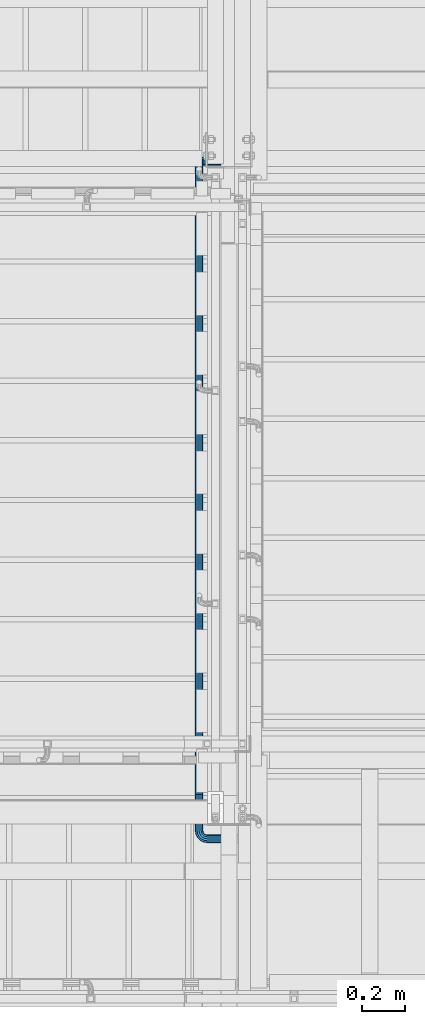
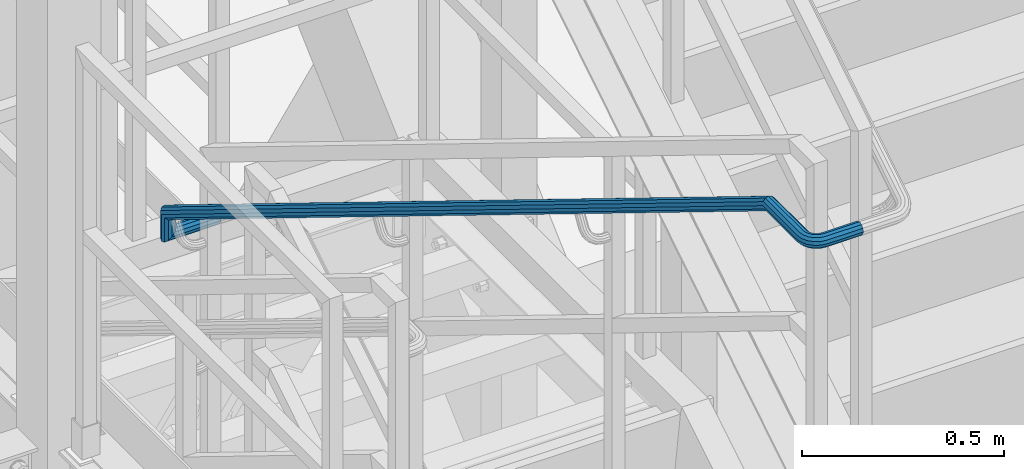
# One storey, part 1764 of 3843: 1 beam, 1 element without a shape of its own.
"""IFC2X3 building model written with IfcOpenShell, lengths in millimetres."""

from ifc_helpers import new_model, si_unit, frame, origin_with_axes, place, context, subcontext, project, spatial, faceted_brep, material, type_object, element, aggregate, save


model = new_model("IFC2X3")

# Units and contexts
model_context = context("Model", 3, precision=1e-05, world=origin_with_axes())
body_context = subcontext(model_context, "Body", "Model", "MODEL_VIEW")
ifc_project = project(units=[si_unit("LENGTHUNIT", "METRE", prefix="MILLI"), si_unit("AREAUNIT", "SQUARE_METRE"), si_unit("VOLUMEUNIT", "CUBIC_METRE"), si_unit("MASSUNIT", "GRAM", prefix="KILO"), si_unit("TIMEUNIT", "SECOND"), si_unit("PLANEANGLEUNIT", "RADIAN"), si_unit("SOLIDANGLEUNIT", "STERADIAN"), si_unit("THERMODYNAMICTEMPERATUREUNIT", "DEGREE_CELSIUS"), si_unit("LUMINOUSINTENSITYUNIT", "LUMEN")], contexts=[model_context])

# Site, building, storey
site_placement = place(None, origin_with_axes())
site = spatial("IfcSite", under=ifc_project, at=site_placement, CompositionType="ELEMENT")
building_placement = place(site_placement, origin_with_axes())
building = spatial("IfcBuilding", under=site, at=building_placement, Name="Undefined", CompositionType="ELEMENT")
storey_placement = place(building_placement, origin_with_axes())
storey = spatial("IfcBuildingStorey", under=building, at=storey_placement, Name="Undefined", CompositionType="ELEMENT", Elevation=0.0)

# Assembly, beam
assembly_placement = place(storey_placement, origin_with_axes())
assembly = element("IfcElementAssembly", 1, at=assembly_placement, inside=storey, Name="RAIL", AssemblyPlace="NOTDEFINED", PredefinedType="RIGID_FRAME")
ifc_material = material(Name="STEEL/A513")
beam_type = type_object("IfcBeamType", PredefinedType="NOTDEFINED")
beam_placement = place(assembly_placement, frame((54381.4, 21932.9, 33973.4769213163), z_axis=(0.0, -1.0, 0.0), x_axis=(-1.0, 0.0, 0.0)))
beam = element("IfcBeam", 2, at=beam_placement, type_object=beam_type, material=ifc_material, Name="GRAB RAIL", context=body_context, shape_type="Brep", body=[
    faceted_brep([(0.0, -19.0500000000029, 0.0), (0.0, -16.4977839420972, -9.52500000000146), (120.149999999972, -16.4977839420972, -9.52500000000146), (120.149999999972, -19.0500000000029, 0.0), (0.0, -9.52500000000146, -16.4977839420972), (120.149999999972, -9.52500000000146, -16.4977839420935), (0.0, 0.0, -19.0499989999989), (120.149999999972, 0.0, -19.0499999999993), (0.0, 9.52500000000146, -16.4977839420972), (120.149999999972, 9.52500000000146, -16.4977839420935), (0.0, 16.4977839420972, -9.52500000000146), (120.149999999972, 16.4977839420972, -9.52500000000146), (0.0, 19.0500000000029, 0.0), (120.149999999972, 19.0500000000029, 0.0), (0.0, 16.4977839420972, 9.52500000000146), (120.149999999972, 16.4977839420972, 9.52500000000146), (0.0, 9.52500000000146, 16.4977839420972), (120.149999999972, 9.52500000000146, 16.4977839420935), (0.0, 0.0, 19.0499989999989), (120.149999999972, 0.0, 19.0499999999993), (0.0, -9.52500000000146, 16.4977839420972), (120.149999999972, -9.52500000000146, 16.4977839420935), (0.0, -16.4977839420972, 9.52500000000146), (120.149999999972, -16.4977839420972, 9.52500000000146), (0.0, -15.875, 0.0), (0.0, -13.7481532850798, 7.9375), (120.149999999972, -13.7481532850798, 7.9375), (120.149999999972, -15.875, 0.0), (0.0, -7.9375, 13.7481532850798), (120.149999999972, -7.9375, 13.7481532850798), (0.0, 0.0, 15.875), (120.149999999972, 0.0, 15.875), (0.0, 7.9375, 13.7481532850798), (120.149999999972, 7.9375, 13.7481532850798), (0.0, 13.7481532850798, 7.9375), (120.149999999972, 13.7481532850798, 7.9375), (0.0, 15.875, 0.0), (120.149999999972, 15.875, 0.0), (0.0, 13.7481532850798, -7.9375), (120.149999999972, 13.7481532850798, -7.9375), (0.0, 7.9375, -13.7481532850798), (120.149999999972, 7.9375, -13.7481532850798), (0.0, 0.0, -15.875), (120.149999999972, 0.0, -15.875), (0.0, -7.9375, -13.7481532850798), (120.149999999972, -7.9375, -13.7481532850798), (0.0, -13.7481532850798, -7.9375), (120.149999999972, -13.7481532850798, -7.9375), (123.202216057878, -16.4977839420972, -9.52500000000146), (120.649999999972, -19.0500000000029, 0.0), (130.174999999974, -9.52500000000146, -16.4977839420935), (139.699999999975, 0.0, -19.0499999999993), (149.224999999977, 9.52500000000146, -16.4977839420935), (156.197783942072, 16.4977839420972, -9.52500000000146), (158.749999999978, 19.0500000000029, 0.0), (156.197783942072, 16.4977839420972, 9.52500000000146), (149.224999999977, 9.52500000000146, 16.4977839420935), (139.699999999975, 0.0, 19.0499999999993), (130.174999999974, -9.52500000000146, 16.4977839420935), (123.202216057878, -16.4977839420972, 9.52500000000146), (125.951846714896, -13.7481532850798, 7.9375), (123.824999999975, -15.875, 0.0), (131.762499999975, -7.9375, 13.7481532850798), (139.699999999975, 0.0, 15.875), (147.637499999975, 7.9375, 13.7481532850798), (153.448153285055, 13.7481532850798, 7.9375), (155.574999999975, 15.875, 0.0), (153.448153285055, 13.7481532850798, -7.9375), (147.637499999975, 7.9375, -13.7481532850798), (139.699999999975, 0.0, -15.875), (131.762499999975, -7.9375, -13.7481532850798), (125.951846714896, -13.7481532850798, -7.9375), (123.202216057878, -19.5500000000029, -9.52500000000146), (120.649999999972, -19.5500000000029, 0.0), (130.174999999974, -19.5500000000029, -16.4977839420935), (139.699999999975, -19.5500000000029, -19.0499999999993), (149.224999999977, -19.5500000000029, -16.4977839420935), (156.197783942072, -19.5500000000029, -9.52500000000146), (158.749999999978, -19.5500000000029, 0.0), (156.197783942072, -19.5500000000029, 9.52500000000146), (149.224999999977, -19.5500000000029, 16.4977839420935), (139.699999999975, -19.5500000000029, 19.0499999999993), (130.174999999974, -19.5500000000029, 16.4977839420935), (123.202216057878, -19.5500000000029, 9.52500000000146), (125.951846714896, -19.5500000000029, 7.9375), (123.824999999975, -19.5500000000029, 0.0), (131.762499999975, -19.5500000000029, 13.7481532850798), (139.699999999975, -19.5500000000029, 15.875), (147.637499999975, -19.5500000000029, 13.7481532850798), (153.448153285055, -19.5500000000029, 7.9375), (155.574999999975, -19.5500000000029, 0.0), (153.448153285055, -19.5500000000029, -7.9375), (147.637499999975, -19.5500000000029, -13.7481532850798), (139.699999999975, -19.5500000000029, -15.875), (131.762499999975, -19.5500000000029, -13.7481532850798), (125.951846714896, -19.5500000000029, -7.9375), (123.202216057878, -51.3780302253144, -9.52500000000146), (120.649999999972, -51.3780302253144, 0.0), (130.174999999974, -51.3780302253144, -16.4977839420935), (139.699999999975, -51.3780302253144, -19.0499999999993), (149.224999999977, -51.3780302253144, -16.4977839420935), (156.197783942072, -51.3780302253144, -9.52500000000146), (158.749999999978, -51.3780302253144, 0.0), (156.197783942072, -51.3780302253144, 9.52500000000146), (149.224999999977, -51.3780302253144, 16.4977839420935), (139.699999999975, -51.3780302253144, 19.0499999999993), (130.174999999974, -51.3780302253144, 16.4977839420935), (123.202216057878, -51.3780302253144, 9.52500000000146), (125.951846714896, -51.3780302253144, 7.9375), (123.824999999975, -51.3780302253144, 0.0), (131.762499999975, -51.3780302253144, 13.7481532850798), (139.699999999975, -51.3780302253144, 15.875), (147.637499999975, -51.3780302253144, 13.7481532850798), (153.448153285055, -51.3780302253144, 7.9375), (155.574999999975, -51.3780302253144, 0.0), (153.448153285055, -51.3780302253144, -7.9375), (147.637499999975, -51.3780302253144, -13.7481532850798), (139.699999999975, -51.3780302253144, -15.875), (131.762499999975, -51.3780302253144, -13.7481532850798), (125.951846714896, -51.3780302253144, -7.9375), (123.202216057878, -67.8456029129011, -9.52500000000146), (120.649999999972, -62.5230786837055, 0.0), (130.174999999974, -71.7419610731886, -16.4977839420935), (139.699999999975, -73.1681271420966, -19.0499999999993), (149.224999999977, -71.7419610731886, -16.4977839420935), (156.197783942072, -67.8456029129011, -9.52500000000146), (158.749999999978, -62.5230786837055, 0.0), (156.197783942072, -57.20055445451, 9.52500000000146), (149.224999999977, -53.3041962942225, 16.4977839420935), (139.699999999975, -51.8780302253144, 19.0499999999993), (130.174999999974, -53.3041962942225, 16.4977839420935), (123.202216057878, -57.20055445451, 9.52500000000146), (125.951846714896, -58.0876418260377, 7.9375), (123.824999999975, -62.5230786837055, 0.0), (131.762499999975, -54.8406766924672, 13.7481532850798), (139.699999999975, -53.6522049683772, 15.875), (147.637499999975, -54.8406766924672, 13.7481532850798), (153.448153285055, -58.0876418260377, 7.9375), (155.574999999975, -62.5230786837055, 0.0), (153.448153285055, -66.9585155413733, -7.9375), (147.637499999975, -70.2054806749438, -13.7481532850798), (139.699999999975, -71.3939523990339, -15.875), (131.762499999975, -70.2054806749438, -13.7481532850798), (125.951846714896, -66.9585155413733, -7.9375), (123.202216057878, -76.4762153519478, 4.49974524361096), (120.649999999972, -68.3641698805441, 9.49177321527532), (130.174999999974, -82.4146447903186, 0.84532713554654), (139.699999999975, -84.5882608233514, -0.492282728053397), (149.224999999977, -82.4146447903186, 0.84532713554654), (156.197783942072, -76.4762153519478, 4.49974524361096), (158.749999999978, -68.3641698805441, 9.49177321527532), (156.197783942072, -60.2521244091404, 14.4838011869397), (149.224999999977, -54.3136949707623, 18.1382192950041), (139.699999999975, -52.1400789377367, 19.475829158604), (130.174999999974, -54.3136949707623, 18.1382192950041), (123.202216057878, -60.2521244091404, 14.4838011869397), (125.951846714896, -61.604131987704, 13.651796524995), (123.824999999975, -68.3641698805441, 9.49177321527532), (131.762499999975, -56.655440789058, 16.6971449483826), (139.699999999975, -54.8440940948713, 17.8118198347147), (147.637499999975, -56.655440789058, 16.6971449483826), (153.448153285055, -61.604131987704, 13.651796524995), (155.574999999975, -68.3641698805441, 9.49177321527532), (153.448153285055, -75.1242077733768, 5.33174990555563), (147.637499999975, -80.0728989720228, 2.286401482168), (139.699999999975, -81.8842456662169, 1.1717265958323), (131.762499999975, -80.0728989720228, 2.286401482168), (125.951846714896, -75.1242077733768, 5.33174990555563), (123.202216057878, -1896.34716333374, 2961.79004207507), (120.649999999972, -1888.23511786234, 2966.78207004673), (130.174999999974, -1902.28559277212, 2958.13562396701), (139.699999999975, -1904.45920880514, 2956.7980141034), (149.224999999977, -1902.28559277212, 2958.13562396701), (156.197783942072, -1896.34716333374, 2961.79004207507), (158.749999999978, -1888.23511786234, 2966.78207004673), (156.197783942072, -1880.12307239093, 2971.7740980184), (149.224999999977, -1874.18464295255, 2975.42851612646), (139.699999999975, -1872.01102691953, 2976.76612599007), (130.174999999974, -1874.18464295255, 2975.42851612646), (123.202216057878, -1880.12307239093, 2971.7740980184), (125.951846714896, -1881.4750799695, 2970.94209335646), (123.824999999975, -1888.23511786234, 2966.78207004673), (131.762499999975, -1876.52638877086, 2973.98744177984), (139.699999999975, -1874.71504207666, 2975.10211666618), (147.637499999975, -1876.52638877086, 2973.98744177984), (153.448153285055, -1881.4750799695, 2970.94209335646), (155.574999999975, -1888.23511786234, 2966.78207004673), (153.448153285055, -1894.99515575518, 2962.62204673701), (147.637499999975, -1899.94384695382, 2959.57669831363), (139.699999999975, -1901.75519364801, 2958.46202342729), (131.762499999975, -1899.94384695382, 2959.57669831363), (125.951846714896, -1894.99515575518, 2962.62204673701), (123.202216057878, -1900.84807563195, 2969.1040245754), (120.649999999972, -1891.32307563195, 2971.80000143316), (130.174999999974, -1907.82085957405, 2967.13043253949), (139.699999999975, -1910.37307563196, 2966.40804771764), (149.224999999977, -1907.82085957405, 2967.13043253949), (156.197783942072, -1900.84807563195, 2969.1040245754), (158.749999999978, -1891.32307563195, 2971.80000143316), (156.197783942072, -1881.79807563195, 2974.49597829091), (149.224999999977, -1874.82529168986, 2976.46957032682), (139.699999999975, -1872.27307563195, 2977.19195514867), (130.174999999974, -1874.82529168986, 2976.46957032682), (123.202216057878, -1881.79807563195, 2974.49597829091), (125.951846714896, -1883.38557563195, 2974.04664881462), (123.824999999975, -1891.32307563195, 2971.80000143316), (131.762499999975, -1877.57492234687, 2975.69130884454), (139.699999999975, -1875.44807563195, 2976.29329619608), (147.637499999975, -1877.57492234687, 2975.69130884454), (153.448153285055, -1883.38557563195, 2974.04664881462), (155.574999999975, -1891.32307563195, 2971.80000143316), (153.448153285055, -1899.26057563195, 2969.55335405169), (147.637499999975, -1905.07122891703, 2967.90869402177), (139.699999999975, -1907.19807563195, 2967.30670667023), (131.762499999975, -1905.07122891703, 2967.90869402177), (125.951846714896, -1899.26057563195, 2969.55335405169), (123.202216057878, -1900.84807563195, 2977.69195514867), (120.649999999972, -1891.32307563195, 2977.69195514867), (130.174999999974, -1907.82085957404, 2977.69195514867), (139.699999999975, -1910.37307563196, 2977.69195514867), (149.224999999977, -1907.82085957404, 2977.69195514867), (156.197783942072, -1900.84807563195, 2977.69195514867), (158.749999999978, -1891.32307563195, 2977.69195514867), (156.197783942072, -1881.79807563195, 2977.69195514867), (149.224999999977, -1874.82529168986, 2977.69195514867), (139.699999999975, -1872.27307563195, 2977.69195514867), (130.174999999974, -1874.82529168986, 2977.69195514867), (123.202216057878, -1881.79807563195, 2977.69195514867), (125.951846714896, -1883.38557563195, 2977.69195514867), (123.824999999975, -1891.32307563195, 2977.69195514867), (131.762499999975, -1877.57492234687, 2977.69195514867), (139.699999999975, -1875.44807563195, 2977.69195514867), (147.637499999975, -1877.57492234687, 2977.69195514867), (153.448153285055, -1883.38557563195, 2977.69195514867), (155.574999999975, -1891.32307563195, 2977.69195514867), (153.448153285055, -1899.26057563195, 2977.69195514867), (147.637499999975, -1905.07122891703, 2977.69195514867), (139.699999999975, -1907.19807563195, 2977.69195514867), (131.762499999975, -1905.07122891703, 2977.69195514867), (125.951846714896, -1899.26057563195, 2977.69195514867), (123.202216057878, -1900.84807563195, 3136.90000152588), (120.649999999972, -1891.32307563195, 3136.90000152588), (130.174999999974, -1907.82085957404, 3136.90000152588), (139.699999999975, -1910.37307563196, 3136.90000152588), (149.224999999977, -1907.82085957404, 3136.90000152588), (156.197783942072, -1900.84807563195, 3136.90000152588), (158.749999999978, -1891.32307563195, 3136.90000152588), (156.197783942072, -1881.79807563195, 3136.90000152588), (149.224999999977, -1874.82529168986, 3136.90000152588), (139.699999999975, -1872.27307563195, 3136.90000152588), (130.174999999974, -1874.82529168986, 3136.90000152588), (123.202216057878, -1881.79807563195, 3136.90000152588), (125.951846714896, -1883.38557563195, 3136.90000152588), (123.824999999975, -1891.32307563195, 3136.90000152588), (131.762499999975, -1877.57492234687, 3136.90000152588), (139.699999999975, -1875.44807563195, 3136.90000152588), (147.637499999975, -1877.57492234687, 3136.90000152588), (153.448153285055, -1883.38557563195, 3136.90000152588), (155.574999999975, -1891.32307563195, 3136.90000152588), (153.448153285055, -1899.26057563195, 3136.90000152588), (147.637499999975, -1905.07122891703, 3136.90000152588), (139.699999999975, -1907.19807563195, 3136.90000152588), (131.762499999975, -1905.07122891703, 3136.90000152588), (125.951846714896, -1899.26057563195, 3136.90000152588), (119.71762671008, -1891.32307563195, 3142.7867747972), (122.144928422946, -1881.79807563195, 3143.57545293241), (128.776440027796, -1874.82529168986, 3145.73016166862), (137.835253345504, -1872.27307563195, 3148.67354854004), (146.894066663219, -1874.82529168986, 3151.61693541146), (153.525578268069, -1881.79807563195, 3153.77164414768), (155.952879980934, -1891.32307563195, 3154.56032228288), (153.525578268069, -1900.84807563195, 3153.77164414768), (146.894066663219, -1907.82085957404, 3151.61693541146), (137.835253345504, -1910.37307563196, 3148.67354854004), (128.776440027796, -1907.82085957404, 3145.73016166862), (122.144928422946, -1900.84807563195, 3143.57545293241), (152.933275541698, -1891.32307563195, 3153.57919332575), (150.910524114304, -1883.38557563195, 3152.9219615464), (145.384264443601, -1877.57492234687, 3151.1263709329), (137.835253345504, -1875.44807563195, 3148.67354854004), (130.286242247414, -1877.57492234687, 3146.22072614719), (124.759982576703, -1883.38557563195, 3144.42513553369), (122.737231149316, -1891.32307563195, 3143.76790375434), (124.759982576703, -1899.26057563195, 3144.42513553369), (130.286242247414, -1905.07122891703, 3146.22072614719), (137.835253345504, -1907.19807563195, 3148.67354854004), (145.384264443601, -1905.07122891703, 3151.1263709329), (150.910524114304, -1899.26057563195, 3152.9219615464), (140.129434648501, -1874.82529168986, 3164.89327326943), (145.770535355761, -1881.79807563195, 3168.99177283802), (132.423547777078, -1872.27307563195, 3159.29461874134), (124.717660905655, -1874.82529168986, 3153.69596421326), (119.076560198395, -1881.79807563195, 3149.59746464467), (117.011774034232, -1891.32307563195, 3148.09730968517), (119.076560198395, -1900.84807563195, 3149.59746464467), (124.717660905655, -1907.82085957404, 3153.69596421326), (132.423547777078, -1910.37307563196, 3159.29461874134), (140.129434648501, -1907.82085957404, 3164.89327326943), (145.770535355761, -1900.84807563195, 3168.99177283802), (147.835321519924, -1891.32307563195, 3170.49192779752), (143.546037425986, -1899.26057563195, 3167.37558048857), (145.266692562785, -1891.32307563195, 3168.62570962149), (138.845120169935, -1905.07122891703, 3163.96016418142), (132.423547777078, -1907.19807563195, 3159.29461874134), (126.001975384228, -1905.07122891703, 3154.62907330127), (121.301058128178, -1899.26057563195, 3151.21365699412), (119.580402991378, -1891.32307563195, 3149.9635278612), (121.301058128178, -1883.38557563195, 3151.21365699412), (126.001975384228, -1877.57492234687, 3154.62907330127), (132.423547777078, -1875.44807563195, 3159.29461874134), (138.845120169935, -1877.57492234687, 3163.96016418142), (143.546037425986, -1883.38557563195, 3167.37558048857), (129.593273269398, -1874.82529168986, 3175.42943464854), (133.691772837978, -1881.79807563195, 3181.0705353558), (123.994618741308, -1872.27307563195, 3167.72354777712), (118.395964213225, -1874.82529168986, 3160.0176609057), (114.297464644638, -1881.79807563195, 3154.37656019844), (112.797309685135, -1891.32307563195, 3152.31177403427), (114.297464644638, -1900.84807563195, 3154.37656019844), (118.395964213225, -1907.82085957404, 3160.0176609057), (123.994618741308, -1910.37307563196, 3167.72354777712), (129.593273269398, -1907.82085957404, 3175.42943464854), (133.691772837978, -1900.84807563195, 3181.0705353558), (135.191927797481, -1891.32307563195, 3183.13532151997), (132.075580488534, -1899.26057563195, 3178.84603742602), (133.325709621451, -1891.32307563195, 3180.56669256283), (128.660164181383, -1905.07122891703, 3174.14512016997), (123.994618741308, -1907.19807563195, 3167.72354777712), (119.329073301233, -1905.07122891703, 3161.30197538427), (115.913656994082, -1899.26057563195, 3156.60105812822), (114.663527861165, -1891.32307563195, 3154.88040299141), (115.913656994082, -1883.38557563195, 3156.60105812822), (119.329073301233, -1877.57492234687, 3161.30197538427), (123.994618741308, -1875.44807563195, 3167.72354777712), (128.660164181383, -1877.57492234687, 3174.14512016997), (132.075580488534, -1883.38557563195, 3178.84603742602), (116.316935411443, -1874.82529168986, 3182.19406666326), (118.471644147656, -1881.79807563195, 3188.82557826811), (113.373548540018, -1872.27307563195, 3173.13525334555), (110.430161668592, -1874.82529168986, 3164.07644002783), (108.275452932379, -1881.79807563195, 3157.44492842298), (107.486774797173, -1891.32307563195, 3155.01762671012), (108.275452932379, -1900.84807563195, 3157.44492842298), (110.430161668592, -1907.82085957404, 3164.07644002783), (113.373548540018, -1910.37307563196, 3173.13525334555), (116.316935411443, -1907.82085957404, 3182.19406666326), (118.471644147656, -1900.84807563195, 3188.82557826811), (119.260322282862, -1891.32307563195, 3191.25287998098), (117.621961546378, -1899.26057563195, 3186.21052411435), (118.279193325725, -1891.32307563195, 3188.23327554174), (115.826370932868, -1905.07122891703, 3180.68426444364), (113.373548540018, -1907.19807563195, 3173.13525334555), (110.920726147167, -1905.07122891703, 3165.58624224745), (109.125135533657, -1899.26057563195, 3160.05998257675), (108.46790375431, -1891.32307563195, 3158.03723114936), (109.125135533657, -1883.38557563195, 3160.05998257675), (110.920726147167, -1877.57492234687, 3165.58624224745), (113.373548540018, -1875.44807563195, 3173.13525334555), (115.826370932868, -1877.57492234687, 3180.68426444364), (117.621961546378, -1883.38557563195, 3186.21052411435), (101.600001525854, -1907.82085957404, 3165.47500000002), (101.600001525854, -1900.84807563195, 3158.50221605792), (101.600001525861, -1910.37307563196, 3175.00000000003), (101.600001525861, -1907.82085957404, 3184.52500000003), (101.600001525861, -1900.84807563195, 3191.49778394212), (101.600001525861, -1891.32307563195, 3194.05000000003), (101.600001525861, -1881.79807563195, 3191.49778394212), (101.600001525861, -1874.82529168986, 3184.52500000003), (101.600001525861, -1872.27307563195, 3175.00000000003), (101.600001525854, -1874.82529168986, 3165.47500000002), (101.600001525854, -1881.79807563195, 3158.50221605792), (101.600001525854, -1891.32307563195, 3155.95), (101.600001525861, -1899.26057563195, 3188.74815328511), (101.600001525861, -1891.32307563195, 3190.87500000003), (101.600001525861, -1905.07122891703, 3182.93750000003), (101.600001525861, -1907.19807563195, 3175.00000000003), (101.600001525854, -1905.07122891703, 3167.06250000002), (101.600001525854, -1899.26057563195, 3161.25184671494), (101.600001525854, -1891.32307563195, 3159.125), (101.600001525854, -1883.38557563195, 3161.25184671494), (101.600001525854, -1877.57492234687, 3167.06250000002), (101.600001525861, -1875.44807563195, 3175.00000000003), (101.600001525861, -1877.57492234687, 3182.93750000003), (101.600001525861, -1883.38557563195, 3188.74815328511), (-2.18278728425503e-11, -1900.84807563195, 3158.50221605791), (-2.18278728425503e-11, -1891.32307563195, 3155.95000000001), (-2.18278728425503e-11, -1907.82085957404, 3165.47500000001), (-2.18278728425503e-11, -1910.37307563196, 3175.00000000001), (-2.18278728425503e-11, -1907.82085957404, 3184.52500000001), (-2.18278728425503e-11, -1900.84807563195, 3191.4977839421), (-2.18278728425503e-11, -1891.32307563195, 3194.05000000001), (-2.18278728425503e-11, -1881.79807563195, 3191.4977839421), (-2.18278728425503e-11, -1874.82529168986, 3184.52500000001), (-2.18278728425503e-11, -1872.27307563195, 3175.00000000001), (-2.18278728425503e-11, -1874.82529168986, 3165.47500000001), (-2.18278728425503e-11, -1881.79807563195, 3158.50221605791), (-2.18278728425503e-11, -1883.38557563195, 3161.25184671493), (-2.18278728425503e-11, -1891.32307563195, 3159.12500000001), (-2.18278728425503e-11, -1877.57492234687, 3167.06250000001), (-2.18278728425503e-11, -1875.44807563195, 3175.00000000001), (-2.18278728425503e-11, -1877.57492234687, 3182.93750000001), (-2.18278728425503e-11, -1883.38557563195, 3188.74815328508), (-2.18278728425503e-11, -1891.32307563195, 3190.87500000001), (-2.18278728425503e-11, -1899.26057563195, 3188.74815328508), (-2.18278728425503e-11, -1905.07122891703, 3182.93750000001), (-2.18278728425503e-11, -1907.19807563195, 3175.00000000001), (-2.18278728425503e-11, -1905.07122891703, 3167.06250000001), (-2.18278728425503e-11, -1899.26057563195, 3161.25184671493)], [[[0, 1, 2, 3]], [[1, 4, 5, 2]], [[4, 6, 7, 5]], [[6, 8, 9, 7]], [[8, 10, 11, 9]], [[10, 12, 13, 11]], [[12, 14, 15, 13]], [[14, 16, 17, 15]], [[16, 18, 19, 17]], [[18, 20, 21, 19]], [[20, 22, 23, 21]], [[22, 0, 3, 23]], [[24, 25, 26, 27]], [[25, 28, 29, 26]], [[28, 30, 31, 29]], [[30, 32, 33, 31]], [[32, 34, 35, 33]], [[34, 36, 37, 35]], [[36, 38, 39, 37]], [[38, 40, 41, 39]], [[40, 42, 43, 41]], [[42, 44, 45, 43]], [[44, 46, 47, 45]], [[46, 24, 27, 47]], [[22, 20, 18, 16, 14, 12, 10, 8, 6, 4, 1, 0], [46, 44, 42, 40, 38, 36, 34, 32, 30, 28, 25, 24]], [[3, 2, 48, 49]], [[2, 5, 50, 48]], [[5, 7, 51, 50]], [[7, 9, 52, 51]], [[9, 11, 53, 52]], [[11, 13, 54, 53]], [[13, 15, 55, 54]], [[15, 17, 56, 55]], [[17, 19, 57, 56]], [[19, 21, 58, 57]], [[21, 23, 59, 58]], [[23, 3, 49, 59]], [[27, 26, 60, 61]], [[26, 29, 62, 60]], [[29, 31, 63, 62]], [[31, 33, 64, 63]], [[33, 35, 65, 64]], [[35, 37, 66, 65]], [[37, 39, 67, 66]], [[39, 41, 68, 67]], [[41, 43, 69, 68]], [[43, 45, 70, 69]], [[45, 47, 71, 70]], [[47, 27, 61, 71]], [[49, 48, 72, 73]], [[48, 50, 74, 72]], [[50, 51, 75, 74]], [[51, 52, 76, 75]], [[52, 53, 77, 76]], [[53, 54, 78, 77]], [[54, 55, 79, 78]], [[55, 56, 80, 79]], [[56, 57, 81, 80]], [[57, 58, 82, 81]], [[58, 59, 83, 82]], [[59, 49, 73, 83]], [[61, 60, 84, 85]], [[60, 62, 86, 84]], [[62, 63, 87, 86]], [[63, 64, 88, 87]], [[64, 65, 89, 88]], [[65, 66, 90, 89]], [[66, 67, 91, 90]], [[67, 68, 92, 91]], [[68, 69, 93, 92]], [[69, 70, 94, 93]], [[70, 71, 95, 94]], [[71, 61, 85, 95]], [[73, 72, 96, 97]], [[72, 74, 98, 96]], [[74, 75, 99, 98]], [[75, 76, 100, 99]], [[76, 77, 101, 100]], [[77, 78, 102, 101]], [[78, 79, 103, 102]], [[79, 80, 104, 103]], [[80, 81, 105, 104]], [[81, 82, 106, 105]], [[82, 83, 107, 106]], [[83, 73, 97, 107]], [[85, 84, 108, 109]], [[84, 86, 110, 108]], [[86, 87, 111, 110]], [[87, 88, 112, 111]], [[88, 89, 113, 112]], [[89, 90, 114, 113]], [[90, 91, 115, 114]], [[91, 92, 116, 115]], [[92, 93, 117, 116]], [[93, 94, 118, 117]], [[94, 95, 119, 118]], [[95, 85, 109, 119]], [[97, 96, 120, 121]], [[96, 98, 122, 120]], [[98, 99, 123, 122]], [[99, 100, 124, 123]], [[100, 101, 125, 124]], [[101, 102, 126, 125]], [[102, 103, 127, 126]], [[103, 104, 128, 127]], [[104, 105, 129, 128]], [[105, 106, 130, 129]], [[106, 107, 131, 130]], [[107, 97, 121, 131]], [[109, 108, 132, 133]], [[108, 110, 134, 132]], [[110, 111, 135, 134]], [[111, 112, 136, 135]], [[112, 113, 137, 136]], [[113, 114, 138, 137]], [[114, 115, 139, 138]], [[115, 116, 140, 139]], [[116, 117, 141, 140]], [[117, 118, 142, 141]], [[118, 119, 143, 142]], [[119, 109, 133, 143]], [[121, 120, 144, 145]], [[120, 122, 146, 144]], [[122, 123, 147, 146]], [[123, 124, 148, 147]], [[124, 125, 149, 148]], [[125, 126, 150, 149]], [[126, 127, 151, 150]], [[127, 128, 152, 151]], [[128, 129, 153, 152]], [[129, 130, 154, 153]], [[130, 131, 155, 154]], [[131, 121, 145, 155]], [[133, 132, 156, 157]], [[132, 134, 158, 156]], [[134, 135, 159, 158]], [[135, 136, 160, 159]], [[136, 137, 161, 160]], [[137, 138, 162, 161]], [[138, 139, 163, 162]], [[139, 140, 164, 163]], [[140, 141, 165, 164]], [[141, 142, 166, 165]], [[142, 143, 167, 166]], [[143, 133, 157, 167]], [[145, 144, 168, 169]], [[144, 146, 170, 168]], [[146, 147, 171, 170]], [[147, 148, 172, 171]], [[148, 149, 173, 172]], [[149, 150, 174, 173]], [[150, 151, 175, 174]], [[151, 152, 176, 175]], [[152, 153, 177, 176]], [[153, 154, 178, 177]], [[154, 155, 179, 178]], [[155, 145, 169, 179]], [[157, 156, 180, 181]], [[156, 158, 182, 180]], [[158, 159, 183, 182]], [[159, 160, 184, 183]], [[160, 161, 185, 184]], [[161, 162, 186, 185]], [[162, 163, 187, 186]], [[163, 164, 188, 187]], [[164, 165, 189, 188]], [[165, 166, 190, 189]], [[166, 167, 191, 190]], [[167, 157, 181, 191]], [[169, 168, 192, 193]], [[168, 170, 194, 192]], [[170, 171, 195, 194]], [[171, 172, 196, 195]], [[172, 173, 197, 196]], [[173, 174, 198, 197]], [[174, 175, 199, 198]], [[175, 176, 200, 199]], [[176, 177, 201, 200]], [[177, 178, 202, 201]], [[178, 179, 203, 202]], [[179, 169, 193, 203]], [[181, 180, 204, 205]], [[180, 182, 206, 204]], [[182, 183, 207, 206]], [[183, 184, 208, 207]], [[184, 185, 209, 208]], [[185, 186, 210, 209]], [[186, 187, 211, 210]], [[187, 188, 212, 211]], [[188, 189, 213, 212]], [[189, 190, 214, 213]], [[190, 191, 215, 214]], [[191, 181, 205, 215]], [[193, 192, 216, 217]], [[192, 194, 218, 216]], [[194, 195, 219, 218]], [[195, 196, 220, 219]], [[196, 197, 221, 220]], [[197, 198, 222, 221]], [[198, 199, 223, 222]], [[199, 200, 224, 223]], [[200, 201, 225, 224]], [[201, 202, 226, 225]], [[202, 203, 227, 226]], [[203, 193, 217, 227]], [[205, 204, 228, 229]], [[204, 206, 230, 228]], [[206, 207, 231, 230]], [[207, 208, 232, 231]], [[208, 209, 233, 232]], [[209, 210, 234, 233]], [[210, 211, 235, 234]], [[211, 212, 236, 235]], [[212, 213, 237, 236]], [[213, 214, 238, 237]], [[214, 215, 239, 238]], [[215, 205, 229, 239]], [[217, 216, 240, 241]], [[216, 218, 242, 240]], [[218, 219, 243, 242]], [[219, 220, 244, 243]], [[220, 221, 245, 244]], [[221, 222, 246, 245]], [[222, 223, 247, 246]], [[223, 224, 248, 247]], [[224, 225, 249, 248]], [[225, 226, 250, 249]], [[226, 227, 251, 250]], [[227, 217, 241, 251]], [[229, 228, 252, 253]], [[228, 230, 254, 252]], [[230, 231, 255, 254]], [[231, 232, 256, 255]], [[232, 233, 257, 256]], [[233, 234, 258, 257]], [[234, 235, 259, 258]], [[235, 236, 260, 259]], [[236, 237, 261, 260]], [[237, 238, 262, 261]], [[238, 239, 263, 262]], [[239, 229, 253, 263]], [[251, 241, 264, 265]], [[250, 251, 265, 266]], [[249, 250, 266, 267]], [[248, 249, 267, 268]], [[247, 248, 268, 269]], [[246, 247, 269, 270]], [[245, 246, 270, 271]], [[244, 245, 271, 272]], [[243, 244, 272, 273]], [[242, 243, 273, 274]], [[240, 242, 274, 275]], [[241, 240, 275, 264]], [[257, 258, 276, 277]], [[256, 257, 277, 278]], [[255, 256, 278, 279]], [[254, 255, 279, 280]], [[252, 254, 280, 281]], [[253, 252, 281, 282]], [[263, 253, 282, 283]], [[262, 263, 283, 284]], [[261, 262, 284, 285]], [[260, 261, 285, 286]], [[259, 260, 286, 287]], [[258, 259, 287, 276]], [[268, 288, 289, 269]], [[267, 290, 288, 268]], [[266, 291, 290, 267]], [[265, 292, 291, 266]], [[264, 293, 292, 265]], [[275, 294, 293, 264]], [[274, 295, 294, 275]], [[273, 296, 295, 274]], [[272, 297, 296, 273]], [[271, 298, 297, 272]], [[270, 299, 298, 271]], [[269, 289, 299, 270]], [[287, 300, 301, 276]], [[286, 302, 300, 287]], [[285, 303, 302, 286]], [[284, 304, 303, 285]], [[283, 305, 304, 284]], [[282, 306, 305, 283]], [[281, 307, 306, 282]], [[280, 308, 307, 281]], [[279, 309, 308, 280]], [[278, 310, 309, 279]], [[277, 311, 310, 278]], [[276, 301, 311, 277]], [[288, 312, 313, 289]], [[290, 314, 312, 288]], [[291, 315, 314, 290]], [[292, 316, 315, 291]], [[293, 317, 316, 292]], [[294, 318, 317, 293]], [[295, 319, 318, 294]], [[296, 320, 319, 295]], [[297, 321, 320, 296]], [[298, 322, 321, 297]], [[299, 323, 322, 298]], [[289, 313, 323, 299]], [[300, 324, 325, 301]], [[302, 326, 324, 300]], [[303, 327, 326, 302]], [[304, 328, 327, 303]], [[305, 329, 328, 304]], [[306, 330, 329, 305]], [[307, 331, 330, 306]], [[308, 332, 331, 307]], [[309, 333, 332, 308]], [[310, 334, 333, 309]], [[311, 335, 334, 310]], [[301, 325, 335, 311]], [[312, 336, 337, 313]], [[314, 338, 336, 312]], [[315, 339, 338, 314]], [[316, 340, 339, 315]], [[317, 341, 340, 316]], [[318, 342, 341, 317]], [[319, 343, 342, 318]], [[320, 344, 343, 319]], [[321, 345, 344, 320]], [[322, 346, 345, 321]], [[323, 347, 346, 322]], [[313, 337, 347, 323]], [[324, 348, 349, 325]], [[326, 350, 348, 324]], [[327, 351, 350, 326]], [[328, 352, 351, 327]], [[329, 353, 352, 328]], [[330, 354, 353, 329]], [[331, 355, 354, 330]], [[332, 356, 355, 331]], [[333, 357, 356, 332]], [[334, 358, 357, 333]], [[335, 359, 358, 334]], [[325, 349, 359, 335]], [[343, 360, 361, 342]], [[344, 362, 360, 343]], [[345, 363, 362, 344]], [[346, 364, 363, 345]], [[347, 365, 364, 346]], [[337, 366, 365, 347]], [[336, 367, 366, 337]], [[338, 368, 367, 336]], [[339, 369, 368, 338]], [[340, 370, 369, 339]], [[341, 371, 370, 340]], [[342, 361, 371, 341]], [[348, 372, 373, 349]], [[350, 374, 372, 348]], [[351, 375, 374, 350]], [[352, 376, 375, 351]], [[353, 377, 376, 352]], [[354, 378, 377, 353]], [[355, 379, 378, 354]], [[356, 380, 379, 355]], [[357, 381, 380, 356]], [[358, 382, 381, 357]], [[359, 383, 382, 358]], [[349, 373, 383, 359]], [[371, 361, 384, 385]], [[361, 360, 386, 384]], [[360, 362, 387, 386]], [[362, 363, 388, 387]], [[363, 364, 389, 388]], [[364, 365, 390, 389]], [[365, 366, 391, 390]], [[366, 367, 392, 391]], [[367, 368, 393, 392]], [[368, 369, 394, 393]], [[369, 370, 395, 394]], [[370, 371, 385, 395]], [[378, 379, 396, 397]], [[379, 380, 398, 396]], [[380, 381, 399, 398]], [[381, 382, 400, 399]], [[382, 383, 401, 400]], [[383, 373, 402, 401]], [[373, 372, 403, 402]], [[372, 374, 404, 403]], [[374, 375, 405, 404]], [[375, 376, 406, 405]], [[376, 377, 407, 406]], [[377, 378, 397, 407]], [[386, 387, 388, 389, 390, 391, 392, 393, 394, 395, 385, 384], [398, 399, 400, 401, 402, 403, 404, 405, 406, 407, 397, 396]]]),
])
aggregate(assembly, [beam])

save(model, "model.ifc")
